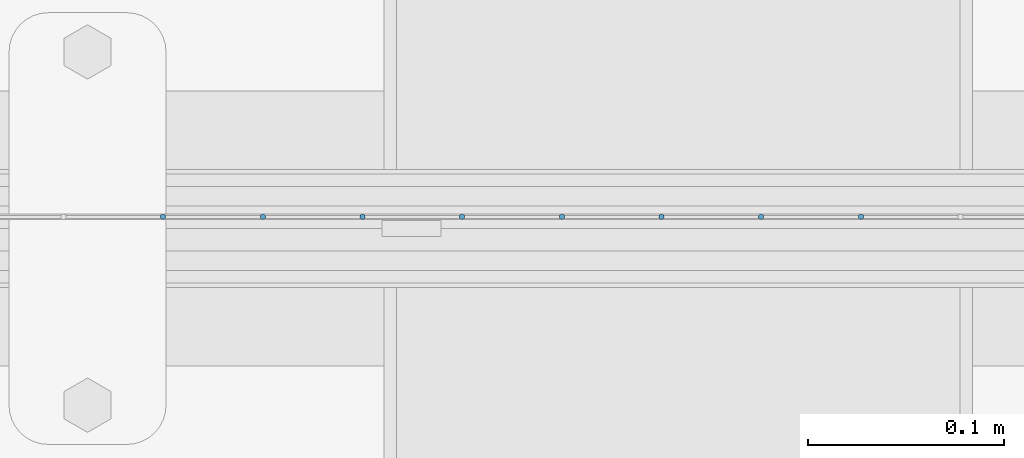
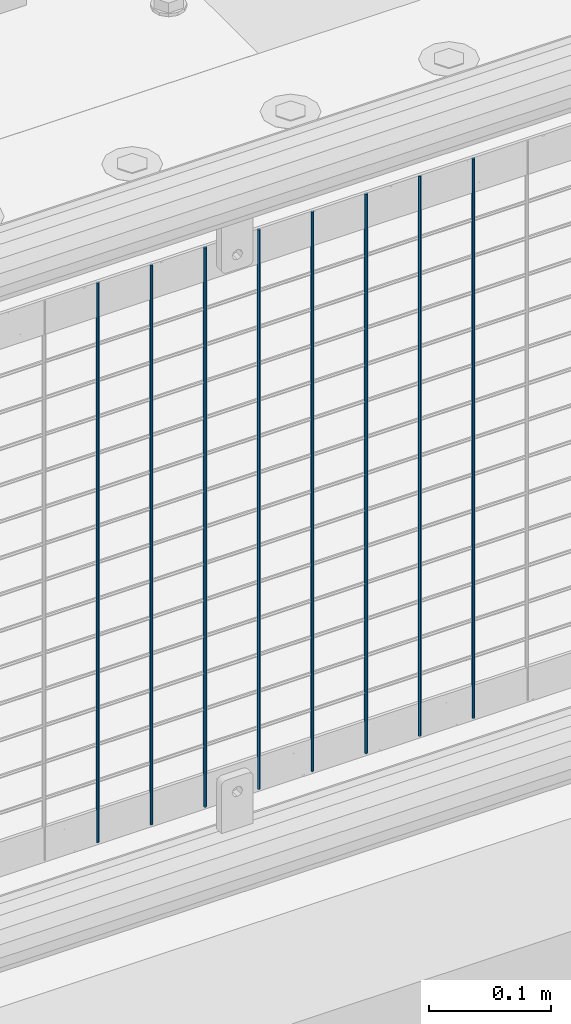
# One storey, part 104 of 270: 8 columns.
"""IFC2X3 building model written with IfcOpenShell, lengths in millimetres."""

from ifc_helpers import new_model, si_unit, frame, origin_with_axes, place, context, subcontext, project, spatial, faceted_brep, material, type_object, element, save


model = new_model("IFC2X3")

# Units and contexts
model_context = context("Model", 3, precision=1e-05, world=origin_with_axes())
body_context = subcontext(model_context, "Body", "Model", "MODEL_VIEW")
ifc_project = project(units=[si_unit("LENGTHUNIT", "METRE", prefix="MILLI"), si_unit("AREAUNIT", "SQUARE_METRE"), si_unit("VOLUMEUNIT", "CUBIC_METRE"), si_unit("MASSUNIT", "GRAM", prefix="KILO"), si_unit("TIMEUNIT", "SECOND"), si_unit("PLANEANGLEUNIT", "RADIAN"), si_unit("SOLIDANGLEUNIT", "STERADIAN"), si_unit("THERMODYNAMICTEMPERATUREUNIT", "DEGREE_CELSIUS"), si_unit("LUMINOUSINTENSITYUNIT", "LUMEN")], contexts=[model_context])

# Site, building, storey
site_placement = place(None, origin_with_axes())
site = spatial("IfcSite", under=ifc_project, at=site_placement, CompositionType="ELEMENT")
building_placement = place(site_placement, origin_with_axes())
building = spatial("IfcBuilding", under=site, at=building_placement, Name="Standard", CompositionType="ELEMENT")
storey_placement = place(building_placement, origin_with_axes())
storey = spatial("IfcBuildingStorey", under=building, at=storey_placement, Name="Undefined", CompositionType="ELEMENT", Elevation=0.0)

# Columns
ifc_material = material(Name="Misc_Undefined")
column_type = type_object("IfcColumnType", Name="D3", PredefinedType="NOTDEFINED")
for number, where, z_axis, x_axis in (
    (1, (16363.067, -16329.5, 353.02), (-1.0, 0.0, 0.0), (0.0, 0.0, 1.0)),
    (2, (16312.274, -16329.5, 353.02), (-1.0, 0.0, 0.0), (0.0, 0.0, 1.0)),
    (3, (16261.481, -16329.5, 353.02), (-1.0, 0.0, 0.0), (0.0, 0.0, 1.0)),
    (4, (16210.688, -16329.5, 353.02), (-1.0, 0.0, 0.0), (0.0, 0.0, 1.0)),
    (5, (16159.895, -16329.5, 353.02), (-1.0, 0.0, 0.0), (0.0, 0.0, 1.0)),
    (6, (16109.102, -16329.5, 353.02), (-1.0, 0.0, 0.0), (0.0, 0.0, 1.0)),
    (7, (16058.309, -16329.5, 353.02), (-1.0, 0.0, 0.0), (0.0, 0.0, 1.0)),
    (8, (16007.516, -16329.5, 353.02), (-1.0, 0.0, 0.0), (0.0, 0.0, 1.0)),
):
    element("IfcColumn", number, at=place(storey_placement, frame(where, z_axis=z_axis, x_axis=x_axis)), inside=storey, type_object=column_type, material=ifc_material, ObjectType="D3", context=body_context, shape_type="Brep", body=[
        faceted_brep([(0.0, -1.5, 0.0), (0.0, -0.75, -1.29903810567669), (560.0, -0.75, -1.29903810567703), (560.0, -1.5, 0.0), (0.0, 0.75, -1.29903810567669), (560.0, 0.75, -1.29903810567703), (0.0, 1.5, 0.0), (560.0, 1.5, 0.0), (0.0, 0.75, 1.29903810567669), (560.0, 0.75, 1.29903810567703), (0.0, -0.75, 1.29903810567669), (560.0, -0.75, 1.29903810567703)], [[[0, 1, 2, 3]], [[1, 4, 5, 2]], [[4, 6, 7, 5]], [[6, 8, 9, 7]], [[8, 10, 11, 9]], [[10, 0, 3, 11]], [[5, 7, 9, 11, 3, 2]], [[10, 8, 6, 4, 1, 0]]]),
    ])

save(model, "model.ifc")
